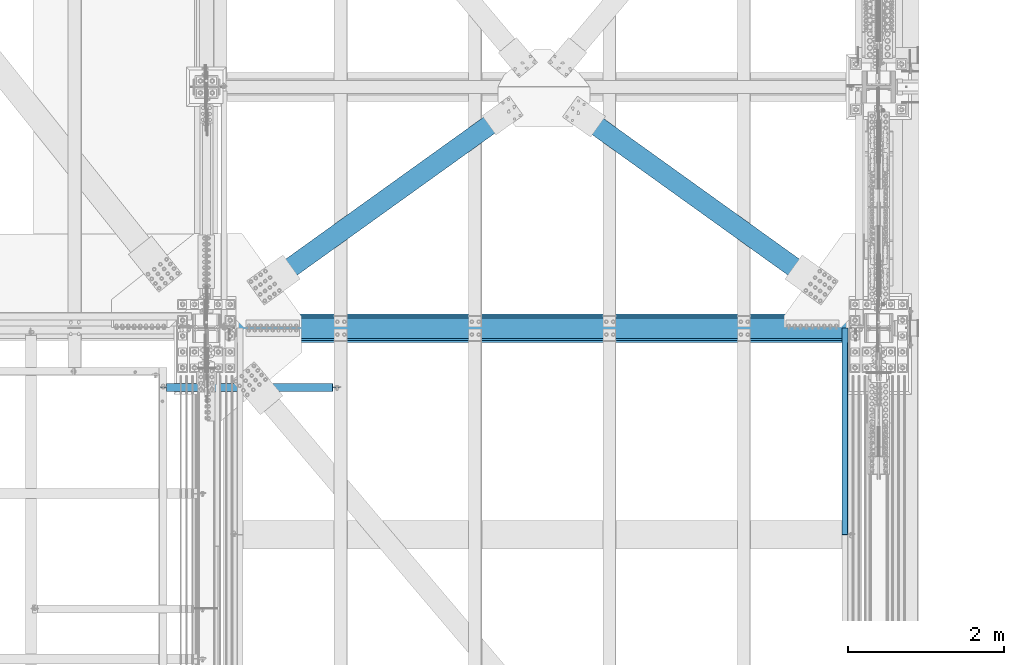
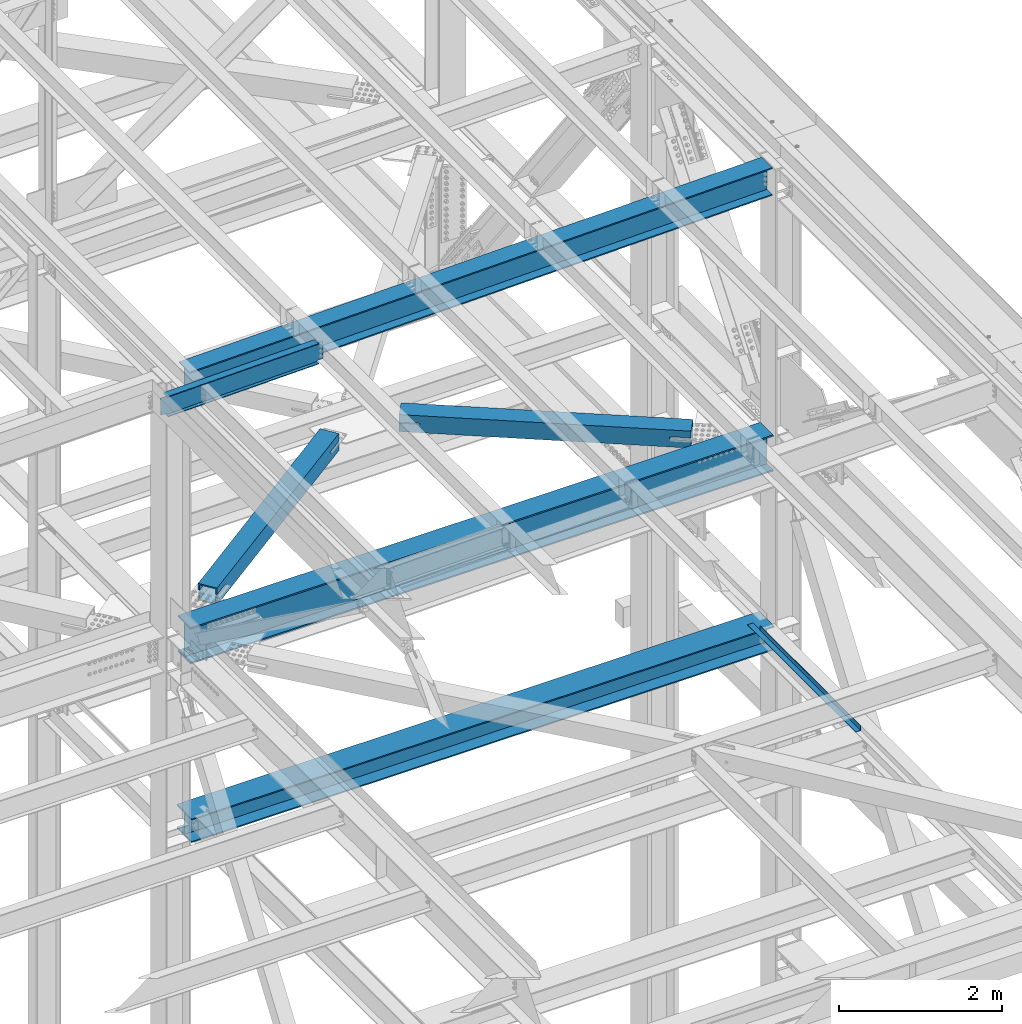
# One storey, part 1954 of 3843: 7 beams, 7 elements without a shape of their own.
"""IFC2X3 building model written with IfcOpenShell, lengths in millimetres."""

from ifc_helpers import new_model, si_unit, frame, origin_with_axes, place, context, subcontext, project, spatial, faceted_brep, material, type_object, element, aggregate, save


model = new_model("IFC2X3")

# Units and contexts
model_context = context("Model", 3, precision=1e-05, world=origin_with_axes())
body_context = subcontext(model_context, "Body", "Model", "MODEL_VIEW")
ifc_project = project(units=[si_unit("LENGTHUNIT", "METRE", prefix="MILLI"), si_unit("AREAUNIT", "SQUARE_METRE"), si_unit("VOLUMEUNIT", "CUBIC_METRE"), si_unit("MASSUNIT", "GRAM", prefix="KILO"), si_unit("TIMEUNIT", "SECOND"), si_unit("PLANEANGLEUNIT", "RADIAN"), si_unit("SOLIDANGLEUNIT", "STERADIAN"), si_unit("THERMODYNAMICTEMPERATUREUNIT", "DEGREE_CELSIUS"), si_unit("LUMINOUSINTENSITYUNIT", "LUMEN")], contexts=[model_context])

# Site, building, storey
site_placement = place(None, origin_with_axes())
site = spatial("IfcSite", under=ifc_project, at=site_placement, CompositionType="ELEMENT")
building_placement = place(site_placement, origin_with_axes())
building = spatial("IfcBuilding", under=site, at=building_placement, Name="Undefined", CompositionType="ELEMENT")
storey_placement = place(building_placement, origin_with_axes())
storey = spatial("IfcBuildingStorey", under=building, at=storey_placement, Name="Undefined", CompositionType="ELEMENT", Elevation=0.0)

# Assembly, beam
assembly_1_placement = place(storey_placement, origin_with_axes())
assembly_1 = element("IfcElementAssembly", 1, at=assembly_1_placement, inside=storey, Name="BEAM", AssemblyPlace="NOTDEFINED", PredefinedType="RIGID_FRAME")
ifc_material_1 = material(Name="STEEL/A992")
beam_type_1 = type_object("IfcBeamType", Name="W21X101", PredefinedType="NOTDEFINED")
beam_1_placement = place(assembly_1_placement, frame((77012.8, 25615.9, 42197.3375), z_axis=(0.0, 0.0, 1.0), x_axis=(1.0, 0.0, 0.0)))
beam_1 = element("IfcBeam", 2, at=beam_1_placement, type_object=beam_type_1, material=ifc_material_1, Name="BEAM", ObjectType="W21X101", context=body_context, shape_type="Brep", body=[
    faceted_brep([(190.5, -155.575000000001, -271.462500000001), (190.5, 155.575000000001, -271.462500000001), (8439.15000000001, 155.575000000001, -271.462500000001), (8439.15000000001, -155.575000000001, -271.462500000001), (190.5, -155.575000000001, -250.824999999997), (190.5, -6.34999999999854, -250.824999999997), (190.5, -6.34999999999854, 250.824999999997), (190.5, -155.575000000001, 250.824999999997), (190.5, -155.575000000001, 271.462500000001), (190.5, 155.575000000001, 271.462500000001), (190.5, 155.575000000001, 250.824999999997), (190.5, 6.34999999999854, 250.824999999997), (190.5, 6.34999999999854, -250.824999999997), (190.5, 155.575000000001, -250.824999999997), (8439.15000000001, -155.575000000001, -250.824999999997), (8439.15000000001, -6.34999999999854, -250.824999999997), (8439.15000000001, -6.34999999999854, 250.824999999997), (8439.15000000001, -155.575000000001, 250.824999999997), (8439.15000000001, -155.575000000001, 271.462500000001), (8439.15000000001, 155.575000000001, 271.462500000001), (8439.15000000001, 155.575000000001, 250.824999999997), (8439.15000000001, 6.34999999999854, 250.824999999997), (8439.15000000001, 6.34999999999854, 207.962500000001), (8439.15000000001, 6.34999999999854, -175.037499999999), (8439.15000000001, 6.34999999999854, -250.824999999997), (8439.15000000001, 155.575000000001, -250.824999999997)], [[[0, 1, 2, 3]], [[0, 4, 5, 6, 7, 8, 9, 10, 11, 12, 13, 1]], [[5, 4, 14, 15]], [[6, 5, 15, 16]], [[7, 6, 16, 17]], [[8, 7, 17, 18]], [[9, 8, 18, 19]], [[10, 9, 19, 20]], [[11, 10, 20, 21]], [[12, 11, 21, 22, 23, 24]], [[13, 12, 24, 25]], [[1, 13, 25, 2]], [[24, 23, 22, 21, 20, 19, 18, 17, 16, 15, 14, 3, 2, 25]], [[4, 0, 3, 14]]]),
])
aggregate(assembly_1, [beam_1])

assembly_2_placement = place(storey_placement, origin_with_axes())
assembly_2 = element("IfcElementAssembly", 3, at=assembly_2_placement, inside=storey, Name="BEAM", AssemblyPlace="NOTDEFINED", PredefinedType="RIGID_FRAME")
beam_type_2 = type_object("IfcBeamType", Name="W12X19", PredefinedType="NOTDEFINED")
beam_2_placement = place(assembly_2_placement, frame((76406.4576296654, 24853.8999999989, 46418.2582400871), z_axis=(-0.0211520980073474, 0.0, 0.999776269347241), x_axis=(0.999776270257024, 0.0, 0.0211520550054619)))
beam_2 = element("IfcBeam", 4, at=beam_2_placement, type_object=beam_type_2, material=ifc_material_1, Name="BEAM", ObjectType="W12X19", context=body_context, shape_type="Brep", body=[
    faceted_brep([(2232.31457436798, -3.17499999999927, -144.462499994821), (2232.31457436798, -50.7999999999993, -144.462499994821), (2232.31457436799, -50.7999999999993, -153.98749999483), (2232.31457436799, 50.7999999999993, -153.98749999483), (2232.31457436798, 50.7999999999993, -144.462499994821), (2232.31457436798, 3.17499999999927, -144.462499994821), (2232.31457436796, 3.17499999999927, -141.287499723039), (2232.31457436796, -3.17499999999927, -141.287499723039), (2233.28130429053, 3.17499999999927, -136.427420204993), (2233.28130429053, -3.17499999999927, -136.427420204993), (2236.03431819094, 3.17499999999927, -132.307243736817), (2236.03431819094, -3.17499999999927, -132.307243736817), (2240.154494659, 3.17499999999927, -129.554229836329), (2240.154494659, -3.17499999999927, -129.554229836329), (2245.01457417695, 3.17499999999927, -128.587499913723), (2245.01457417695, -3.17499999999927, -128.587499913723), (2314.86448693209, -3.17499999999927, -128.587499913519), (2314.86448693209, 3.17499999999927, -128.587499913519), (96.8369960211567, 3.17499999999927, 144.4625000003), (96.8369960211567, 50.7999999999993, 144.4625000003), (2232.3145743674, 50.7999999999993, 144.462500005327), (2232.3145743674, 3.17499999999927, 144.462500005327), (96.8369999801071, -3.17499999999927, -141.287529930967), (96.8369999801071, 3.17499999999927, -141.287529930967), (96.8369989925268, 3.17499999999927, -144.462499999849), (96.8369989925268, 50.7999999999993, -144.462499999849), (96.8369960297132, 50.7999999999993, -153.987499999843), (96.8369960297132, -50.7999999999993, -153.987499999843), (96.8369989925268, -50.7999999999993, -144.462499999849), (96.8369989925268, -3.17499999999927, -144.462499999849), (95.8702715693071, -3.17499999999927, -136.42745011222), (95.8702715693071, 3.17499999999927, -136.42745011222), (93.1172589504567, -3.17499999999927, -132.30727278773), (93.1172589504567, 3.17499999999927, -132.30727278773), (88.997083338676, -3.17499999999927, -129.55425760564), (88.997083338676, 3.17499999999927, -129.55425760564), (84.1370041213813, -3.17499999999927, -128.587526171294), (84.1370041213813, 3.17499999999927, -128.587526171294), (20.637003929136, -3.17499999999927, -128.587506419208), (20.637003929136, 3.17499999999927, -128.587506419208), (20.6370839253505, -3.17499999999927, 128.587493580635), (20.6370839253505, 3.17499999999927, 128.587493580635), (20.6370799748984, 3.17499999999927, 115.887493577924), (20.6370082450449, 3.17499999999927, -114.71250641709), (84.1369962121535, -3.17499999999927, 128.58750000054), (84.1369962121535, 3.17499999999927, 128.58750000054), (88.9970757301198, -3.17499999999927, 129.554229923146), (88.9970757301198, 3.17499999999927, 129.554229923146), (93.1172521981789, -3.17499999999927, 132.307243823634), (93.1172521981789, 3.17499999999927, 132.307243823634), (95.8702660985873, -3.17499999999927, 136.427420291802), (95.8702660985873, 3.17499999999927, 136.427420291802), (96.8369960211421, -3.17499999999927, 141.287499809849), (96.8369960211421, 3.17499999999927, 141.287499809849), (96.8369960211276, -50.7999999999993, 153.988180121596), (96.8369960211276, 50.7999999999993, 153.987500000301), (96.8369960211567, -3.17499999999927, 144.4625000003), (96.8369960211567, -50.7999999999993, 144.4625000003), (2232.3145743674, -3.17499999999927, 144.462500005327), (2232.3145743674, -50.7999999999993, 144.462500005327), (2232.31457436738, -50.7999999999993, 153.987525317927), (2232.31457436738, 50.7999999999993, 153.987500005329), (2232.3145743674, -3.17499999999927, 141.287499895916), (2232.3145743674, 3.17499999999927, 141.287499895916), (2233.28130428997, -3.17499999999927, 136.42742037787), (2233.28130428997, 3.17499999999927, 136.42742037787), (2236.03431819039, -3.17499999999927, 132.307243909716), (2236.03431819039, 3.17499999999927, 132.307243909716), (2240.15449465848, -3.17499999999927, 129.554230009235), (2240.15449465848, 3.17499999999927, 129.554230009235), (2245.01457417643, -3.17499999999927, 128.587500086658), (2245.01457417643, 3.17499999999927, 128.587500086658), (2314.8645669283, -3.17499999999927, 128.587500086825), (2314.8645669283, 3.17499999999927, 128.587500086825), (2314.86449124801, 3.17499999999927, -114.712513824932), (2314.86456297785, 3.17499999999927, 115.887486172294)], [[[0, 1, 2, 3, 4, 5, 6, 7]], [[7, 6, 8, 9]], [[9, 8, 10, 11]], [[11, 10, 12, 13]], [[13, 12, 14, 15]], [[16, 15, 14, 17]], [[18, 19, 20, 21]], [[22, 23, 24, 25, 26, 27, 28, 29]], [[30, 31, 23, 22]], [[32, 33, 31, 30]], [[34, 35, 33, 32]], [[36, 37, 35, 34]], [[38, 39, 37, 36]], [[40, 41, 42, 43, 39, 38]], [[44, 45, 41, 40]], [[46, 47, 45, 44]], [[48, 49, 47, 46]], [[50, 51, 49, 48]], [[52, 53, 51, 50]], [[54, 55, 19, 18, 53, 52, 56, 57]], [[57, 56, 58, 59]], [[54, 57, 59, 60]], [[55, 54, 60, 61]], [[19, 55, 61, 20]], [[60, 59, 58, 62, 63, 21, 20, 61]], [[64, 65, 63, 62]], [[66, 67, 65, 64]], [[68, 69, 67, 66]], [[70, 71, 69, 68]], [[72, 73, 71, 70]], [[74, 75, 73, 72, 16, 17]], [[12, 10, 8, 6, 5, 24, 23, 31, 33, 35, 37, 39, 43, 42, 41, 45, 47, 49, 51, 53, 18, 21, 63, 65, 67, 69, 71, 73, 75, 74, 17, 14]], [[25, 24, 5, 4]], [[26, 25, 4, 3]], [[27, 26, 3, 2]], [[28, 27, 2, 1]], [[29, 28, 1, 0]], [[72, 70, 68, 66, 64, 62, 58, 56, 52, 50, 48, 46, 44, 40, 38, 36, 34, 32, 30, 22, 29, 0, 7, 9, 11, 13, 15, 16]]]),
])
aggregate(assembly_2, [beam_2])

assembly_3_placement = place(storey_placement, origin_with_axes())
assembly_3 = element("IfcElementAssembly", 5, at=assembly_3_placement, inside=storey, Name="BENT_PLATE", AssemblyPlace="NOTDEFINED", PredefinedType="RIGID_FRAME")
ifc_material_2 = material(Name="STEEL/A36")
beam_type_3 = type_object("IfcBeamType", PredefinedType="NOTDEFINED")
beam_3_placement = place(assembly_3_placement, frame((85177.3124999996, 24288.75, 39627.1750000005), z_axis=(0.0, 1.0, 0.0), x_axis=(1.0, 0.0, 0.0)))
beam_3 = element("IfcBeam", 6, at=beam_3_placement, type_object=beam_type_3, material=ifc_material_2, Name="BENT_PLATE", context=body_context, shape_type="Brep", body=[
    faceted_brep([(73.0249999527732, -4.71118255518377e-08, -1327.15), (69.8499999999767, -3.17499999968277, -1323.97500004769), (1.45519152283669e-11, -3.17500000000291, -1323.97500004769), (0.0, -4.74465196020901e-08, -1327.15), (73.0249999533989, -73.024999999252, -1327.15), (69.8500000005733, -73.0249999992811, -1323.97500004769), (69.8499999999767, -3.17499999968277, 1142.99999999999), (69.8499999999767, -3.17499999968277, 1327.15), (1.45519152283669e-11, -3.17500000000291, 1327.15), (76.2000000005792, -73.0249999992229, 1143.0), (76.1999999999825, -3.17499999977008, 1142.99999999999), (69.8500000005733, -73.0249999992811, 1143.0), (76.1999999999825, -3.1749999997628, 1327.14999999999), (-1.45519152283669e-11, 3.17500000000291, -1327.15), (76.1999999999243, 3.17500000035216, -1327.15), (76.2000000005792, -73.0249999992229, -1327.15), (-1.45519152283669e-11, 3.17500000000291, 1327.15), (76.1999999999243, 3.17500000035216, 1327.15)], [[[0, 1, 2, 3]], [[4, 5, 1, 0]], [[6, 7, 8, 2, 1]], [[9, 10, 6, 11]], [[12, 7, 6, 10]], [[13, 14, 15, 4, 0, 3]], [[8, 16, 13, 3, 2]], [[13, 16, 17, 14]], [[9, 15, 14, 17, 12, 10]], [[15, 9, 11, 5, 4]], [[11, 6, 1, 5]], [[17, 16, 8, 7, 12]]]),
])
aggregate(assembly_3, [beam_3])

assembly_4_placement = place(storey_placement, origin_with_axes())
assembly_4 = element("IfcElementAssembly", 7, at=assembly_4_placement, inside=storey, AssemblyPlace="NOTDEFINED", PredefinedType="RIGID_FRAME")
ifc_material_3 = material()
beam_type_4 = type_object("IfcBeamType", Name="HSS10X10X3/4", PredefinedType="NOTDEFINED")
beam_4_placement = place(assembly_4_placement, frame((81330.8000041454, 28714.7000040427, 42246.55), z_axis=(0.583045051917548, 0.812439823885107, 0.0), x_axis=(0.81243982388511, -0.583045051917543, 0.0)))
beam_4 = element("IfcBeam", 8, at=beam_4_placement, type_object=beam_type_4, material=ifc_material_3, ObjectType="HSS10X10X3/4", context=body_context, shape_type="Brep", body=[
    faceted_brep([(832.719836871249, 1.58750000000146, 127.000000000786), (832.719836871307, 1.58750000000146, 107.950000000856), (875.816558129489, 1.58750000000146, 107.950000000914), (875.816558129431, 1.58750000000146, 127.000000000844), (878.8541078739, 0.983293789307936, 107.950000000914), (878.854107873842, 0.983293789307936, 127.000000000844), (881.429218205194, -0.737339924329717, 107.950000000928), (881.429218205121, -0.737339924329717, 127.000000000844), (883.149851918824, -3.31245025560202, 107.950000000928), (883.149851918752, -3.31245025560202, 127.000000000844), (875.816558129431, -14.2874999999985, 127.000000000844), (875.816558129489, -14.2874999999985, 107.950000000914), (832.719836871307, -14.2874999999985, 107.950000000856), (832.719836871249, -14.2874999999985, 127.000000000786), (878.854107873842, -13.683293789305, 127.000000000844), (878.8541078739, -13.683293789305, 107.950000000914), (881.429218205121, -11.9626600756674, 127.000000000844), (881.429218205194, -11.9626600756674, 107.950000000928), (883.149851918752, -9.38754974439507, 127.000000000844), (883.149851918824, -9.38754974439507, 107.950000000928), (883.754058129467, -6.34999999999854, 127.000000000859), (883.754058129525, -6.34999999999854, 107.950000000914), (832.719836872006, 1.58750000000146, -107.949999998309), (832.719836872064, 1.58750000000146, -126.999999998239), (875.816558130238, 1.58750000000146, -126.999999998166), (875.81655813018, 1.58750000000146, -107.949999998236), (878.854107874657, 0.983293789307936, -126.999999998166), (878.854107874598, 0.983293789307936, -107.949999998236), (881.429218205936, -0.737339924329717, -126.999999998166), (881.429218205878, -0.737339924329717, -107.949999998236), (883.149851919581, -3.31245025560202, -126.999999998166), (883.149851919508, -3.31245025560202, -107.949999998236), (875.81655813018, -14.2874999999985, -107.949999998236), (875.816558130238, -14.2874999999985, -126.999999998166), (832.719836872064, -14.2874999999985, -126.999999998239), (832.719836872006, -14.2874999999985, -107.949999998309), (878.854107874598, -13.683293789305, -107.949999998236), (878.854107874657, -13.683293789305, -126.999999998166), (881.429218205878, -11.9626600756674, -107.949999998236), (881.429218205936, -11.9626600756674, -126.999999998166), (883.149851919508, -9.38754974439507, -107.949999998236), (883.149851919581, -9.38754974439507, -126.999999998166), (883.754058130216, -6.34999999999854, -107.949999998236), (883.75405813026, -6.34999999999854, -126.999999998166), (623.404058128544, 127.0, -126.999999998559), (623.404058128326, 127.0, 127.000000000451), (4220.92128598434, 127.0, 127.000000005952), (4220.92128598454, 127.0, -126.999999993059), (623.404058128326, -127.0, 127.000000000451), (623.404058128544, -127.0, -126.999999998559), (4220.92128598454, -127.0, -126.999999993059), (4220.92128598434, -127.0, 127.000000005952), (4220.92128598453, 1.58750000000146, -107.949999993143), (3968.5087863602, 1.58750000000146, -107.949999993521), (3968.50878636027, 1.58750000000146, -126.999999993452), (4220.92128598454, 1.58750000000146, -126.999999993059), (3963.04119667428, 0.499928791716229, -107.949999993521), (3963.04119667436, 0.499928791716229, -126.999999993452), (3958.40599795424, -2.59721197552426, -107.949999993536), (3958.40599795429, -2.59721197552426, -126.999999993452), (3955.30885718697, -7.23241069557116, -107.949999993551), (3955.30885718704, -7.23241069557116, -126.999999993466), (3954.2212859787, -12.6999996185259, -107.949999993536), (3954.22128597875, -12.6999996185259, -126.999999993481), (3955.30885718697, -18.167589304423, -107.949999993551), (3955.30885718704, -18.167589304423, -126.999999993466), (3958.40599795424, -22.8027880244699, -107.949999993536), (3958.40599795429, -22.8027880244699, -126.999999993452), (3963.04119667428, -25.8999287917104, -107.949999993521), (3963.04119667436, -25.8999287917104, -126.999999993452), (3968.5087863602, -26.9874999999956, -107.949999993521), (3968.50878636027, -26.9874999999956, -126.999999993452), (4220.92128598453, -26.9874999999956, -107.949999993143), (4220.92128598454, -26.9874999999956, -126.999999993059), (623.40405812853, -107.949999999997, -107.949999998629), (623.404058128341, -107.949999999997, 107.950000000521), (4220.92128598435, -107.949999999997, 107.950000006022), (4220.92128598453, -107.949999999997, -107.949999993143), (4220.92128598435, -26.9874999999956, 107.950000006022), (4220.92128598434, -26.9874999999956, 127.000000005952), (3968.50878635952, -26.9874999999956, 107.950000005629), (3968.50878635946, -26.9874999999956, 127.000000005559), (3963.0411966736, -25.8999287917104, 107.950000005629), (3963.04119667354, -25.8999287917104, 127.000000005559), (3958.40599795354, -22.8027880244699, 107.950000005629), (3958.40599795348, -22.8027880244699, 127.000000005544), (3955.30885718628, -18.167589304423, 107.950000005614), (3955.30885718621, -18.167589304423, 127.000000005544), (3954.22128597799, -12.6999996185259, 107.950000005614), (3954.22128597795, -12.6999996185259, 127.000000005544), (3955.30885718628, -7.23241069557116, 107.950000005614), (3955.30885718621, -7.23241069557116, 127.000000005544), (3958.40599795354, -2.59721197552426, 107.950000005629), (3958.40599795348, -2.59721197552426, 127.000000005544), (3963.0411966736, 0.499928791716229, 107.950000005629), (3963.04119667354, 0.499928791716229, 127.000000005559), (3968.50878635952, 1.58750000000146, 107.950000005629), (3968.50878635946, 1.58750000000146, 127.000000005559), (4220.92128598434, 1.58750000000146, 127.000000005952), (4220.92128598435, 1.58750000000146, 107.950000006022), (4220.92128598435, 107.949999999997, 107.950000006022), (4220.92128598453, 107.949999999997, -107.949999993143), (623.404058128341, 107.949999999997, 107.950000000521), (623.40405812853, 107.949999999997, -107.949999998629), (623.404058128544, 1.58750000000146, -126.999999998559), (623.40405812853, 1.58750000000146, -107.949999998629), (623.404058128341, 1.58750000000146, 107.950000000521), (623.404058128326, 1.58750000000146, 127.000000000451), (623.404058128326, -14.2874999999985, 127.000000000451), (623.404058128341, -14.2874999999985, 107.950000000521), (623.40405812853, -14.2874999999985, -107.949999998629), (623.404058128544, -14.2874999999985, -126.999999998559)], [[[0, 1, 2, 3]], [[3, 2, 4, 5]], [[5, 4, 6, 7]], [[7, 6, 8, 9]], [[10, 11, 12, 13]], [[14, 15, 11, 10]], [[16, 17, 15, 14]], [[18, 19, 17, 16]], [[20, 21, 19, 18]], [[9, 8, 21, 20]], [[22, 23, 24, 25]], [[25, 24, 26, 27]], [[27, 26, 28, 29]], [[29, 28, 30, 31]], [[32, 33, 34, 35]], [[36, 37, 33, 32]], [[38, 39, 37, 36]], [[40, 41, 39, 38]], [[42, 43, 41, 40]], [[31, 30, 43, 42]], [[44, 45, 46, 47]], [[48, 49, 50, 51]], [[52, 53, 54, 55]], [[56, 57, 54, 53]], [[58, 59, 57, 56]], [[60, 61, 59, 58]], [[62, 63, 61, 60]], [[64, 65, 63, 62]], [[66, 67, 65, 64]], [[68, 69, 67, 66]], [[70, 71, 69, 68]], [[72, 73, 71, 70]], [[74, 75, 76, 77]], [[51, 50, 73, 72, 77, 76, 78, 79]], [[79, 78, 80, 81]], [[81, 80, 82, 83]], [[83, 82, 84, 85]], [[85, 84, 86, 87]], [[87, 86, 88, 89]], [[89, 88, 90, 91]], [[91, 90, 92, 93]], [[93, 92, 94, 95]], [[95, 94, 96, 97]], [[98, 97, 96, 99]], [[100, 101, 52, 55, 47, 46, 98, 99]], [[102, 103, 101, 100]], [[45, 44, 104, 105, 103, 102, 106, 107]], [[107, 106, 1, 0]], [[16, 14, 10, 13, 108, 48, 51, 79, 81, 83, 85, 87, 89, 91, 93, 95, 97, 98, 46, 45, 107, 0, 3, 5, 7, 9, 20, 18]], [[6, 4, 2, 1, 106, 102, 100, 99, 96, 94, 92, 90, 88, 86, 84, 82, 80, 78, 76, 75, 109, 12, 11, 15, 17, 19, 21, 8]], [[13, 12, 109, 108]], [[75, 74, 110, 111, 49, 48, 108, 109]], [[35, 34, 111, 110]], [[28, 26, 24, 23, 104, 44, 47, 55, 54, 57, 59, 61, 63, 65, 67, 69, 71, 73, 50, 49, 111, 34, 33, 37, 39, 41, 43, 30]], [[105, 104, 23, 22]], [[38, 36, 32, 35, 110, 74, 77, 72, 70, 68, 66, 64, 62, 60, 58, 56, 53, 52, 101, 103, 105, 22, 25, 27, 29, 31, 42, 40]]]),
])
aggregate(assembly_4, [beam_4])

assembly_5_placement = place(storey_placement, origin_with_axes())
assembly_5 = element("IfcElementAssembly", 9, at=assembly_5_placement, inside=storey, AssemblyPlace="NOTDEFINED", PredefinedType="RIGID_FRAME")
beam_5_placement = place(assembly_5_placement, frame((77012.8, 25615.9, 42246.55), z_axis=(0.583045050783809, -0.812439824698731, 0.0), x_axis=(0.812439824698741, 0.583045050783796, 0.0)))
beam_5 = element("IfcBeam", 10, at=beam_5_placement, type_object=beam_type_4, material=ifc_material_3, ObjectType="HSS10X10X3/4", context=body_context, shape_type="Brep", body=[
    faceted_brep([(4482.13534065839, 14.2874999999985, 127.000000001219), (4469.43534061559, 14.2874999999985, 127.000000001219), (4469.43534061576, 14.2874999999985, 107.950000001289), (4482.13534065855, 14.2874999999985, 107.950000001289), (4466.39779087117, 13.683293789305, 127.000000001215), (4466.39779087133, 13.683293789305, 107.950000001285), (4463.82268053987, 11.9626600756674, 127.000000001219), (4463.82268054002, 11.9626600756674, 107.950000001285), (4462.1020468262, 9.38754974439507, 127.000000001211), (4462.10204682636, 9.38754974439507, 107.950000001281), (4461.4978406155, 6.34999999999854, 127.000000001215), (4461.49784061566, 6.34999999999854, 107.950000001281), (4462.1020468262, 3.31245025560202, 127.000000001211), (4462.10204682636, 3.31245025560202, 107.950000001281), (4463.82268053987, 0.737339924329717, 127.000000001219), (4463.82268054002, 0.737339924329717, 107.950000001285), (4466.39779087117, -0.983293789307936, 127.000000001215), (4466.39779087133, -0.983293789307936, 107.950000001285), (4469.43534061559, -1.58750000000146, 127.000000001219), (4469.43534061576, -1.58750000000146, 107.950000001289), (4482.13534065839, -1.58750000000146, 127.000000001219), (4482.13534065855, -1.58750000000146, 107.950000001289), (4482.13534066027, 14.2874999999985, -107.949999997931), (4469.43534061746, 14.2874999999985, -107.949999997938), (4469.43534061762, 14.2874999999985, -126.999999997868), (4482.13534066042, 14.2874999999985, -126.999999997865), (4466.39779087304, 13.683293789305, -107.949999997938), (4466.39779087319, 13.683293789305, -126.999999997868), (4463.82268054174, 11.9626600756674, -107.949999997934), (4463.8226805419, 11.9626600756674, -126.999999997861), (4462.10204682808, 9.38754974439507, -107.949999997938), (4462.10204682824, 9.38754974439507, -126.999999997865), (4461.49784061739, 6.34999999999854, -107.949999997934), (4461.49784061754, 6.34999999999854, -126.999999997865), (4462.10204682808, 3.31245025560202, -107.949999997938), (4462.10204682824, 3.31245025560202, -126.999999997865), (4463.82268054174, 0.737339924329717, -107.949999997934), (4463.8226805419, 0.737339924329717, -126.999999997861), (4466.39779087304, -0.983293789307936, -107.949999997938), (4466.39779087319, -0.983293789307936, -126.999999997868), (4469.43534061746, -1.58750000000146, -107.949999997938), (4469.43534061762, -1.58750000000146, -126.999999997868), (4482.13534066027, -1.58750000000146, -107.949999997931), (4482.13534066042, -1.58750000000146, -126.999999997865), (1093.93388031794, -107.949999999997, -107.9499999992), (1093.93388031713, -107.949999999997, 107.950000000023), (4721.84784061975, -107.949999999997, 107.950000001376), (4721.84784062057, -107.949999999997, -107.949999997847), (1346.34637994521, -1.58750000000146, -107.949999999102), (1346.34637994536, -1.58750000000146, -126.999999999032), (1093.93388031801, -1.58750000000146, -126.999999999138), (1093.93388031794, -1.58750000000146, -107.9499999992), (1351.81396963117, -0.499928791716229, -107.949999999099), (1351.81396963132, -0.499928791716229, -126.999999999036), (1356.44916835126, 2.59721197552426, -107.949999999102), (1356.44916835142, 2.59721197552426, -126.999999999029), (1359.54630911854, 7.23241069557116, -107.949999999095), (1359.54630911868, 7.23241069557116, -126.999999999032), (1360.63388032683, 12.6999996185259, -107.949999999095), (1360.63388032698, 12.6999996185259, -126.99999999904), (1359.54630911854, 18.167589304423, -107.949999999095), (1359.54630911868, 18.167589304423, -126.999999999032), (1356.44916835126, 22.8027880244699, -107.949999999102), (1356.44916835142, 22.8027880244699, -126.999999999029), (1351.81396963117, 25.8999287917104, -107.949999999099), (1351.81396963132, 25.8999287917104, -126.999999999036), (1346.34637994521, 26.9874999999956, -107.949999999102), (1346.34637994536, 26.9874999999956, -126.999999999032), (1093.93388031794, 26.9874999999956, -107.9499999992), (1093.93388031801, 26.9874999999956, -126.999999999138), (1093.93388031713, 107.949999999997, 107.950000000023), (1093.93388031794, 107.949999999997, -107.9499999992), (4721.84784062057, 107.949999999997, -107.949999997847), (4721.84784061975, 107.949999999997, 107.950000001376), (1351.81396962929, -0.499928791716229, 127.000000000055), (1351.81396962945, -0.499928791716229, 107.950000000117), (1346.3463799435, -1.58750000000146, 107.950000000114), (1346.34637994334, -1.58750000000146, 127.000000000051), (1356.4491683494, 2.59721197552426, 127.000000000051), (1356.44916834954, 2.59721197552426, 107.950000000117), (1359.54630911667, 7.23241069557116, 127.000000000051), (1359.54630911682, 7.23241069557116, 107.950000000121), (1360.63388032497, 12.6999996185259, 127.000000000051), (1360.63388032511, 12.6999996185259, 107.950000000124), (1359.54630911667, 18.167589304423, 127.000000000051), (1359.54630911682, 18.167589304423, 107.950000000121), (1356.4491683494, 22.8027880244699, 127.000000000051), (1356.44916834954, 22.8027880244699, 107.950000000117), (1351.81396962929, 25.8999287917104, 127.000000000055), (1351.81396962945, 25.8999287917104, 107.950000000117), (1346.34637994334, 26.9874999999956, 127.000000000051), (1346.3463799435, 26.9874999999956, 107.950000000114), (1093.93388031707, 26.9874999999956, 126.999999999953), (1093.93388031713, 26.9874999999956, 107.950000000023), (1093.93388031707, 127.0, 126.999999999953), (1093.93388031801, 127.0, -126.999999999138), (4721.84784061968, 127.0, 127.00000000131), (4721.84784062064, 127.0, -126.999999997774), (4721.84784062057, 14.2874999999985, -107.949999997847), (4721.84784062064, 14.2874999999985, -126.999999997774), (4721.84784061968, 14.2874999999985, 127.00000000131), (4721.84784061975, 14.2874999999985, 107.950000001376), (4721.84784061975, -1.58750000000146, 107.950000001376), (1093.93388031713, -1.58750000000146, 107.950000000023), (1093.93388031707, -1.58750000000146, 126.999999999953), (1093.93388031801, -127.0, -126.999999999138), (1093.93388031707, -127.0, 126.999999999953), (4721.84784062064, -127.0, -126.999999997774), (4721.84784061968, -127.0, 127.00000000131), (4721.84784061968, -1.58750000000146, 127.00000000131), (4721.84784062064, -1.58750000000146, -126.999999997774), (4721.84784062057, -1.58750000000146, -107.949999997847)], [[[0, 1, 2, 3]], [[4, 5, 2, 1]], [[6, 7, 5, 4]], [[8, 9, 7, 6]], [[10, 11, 9, 8]], [[12, 13, 11, 10]], [[14, 15, 13, 12]], [[16, 17, 15, 14]], [[18, 19, 17, 16]], [[20, 21, 19, 18]], [[22, 23, 24, 25]], [[26, 27, 24, 23]], [[28, 29, 27, 26]], [[30, 31, 29, 28]], [[32, 33, 31, 30]], [[34, 35, 33, 32]], [[36, 37, 35, 34]], [[38, 39, 37, 36]], [[40, 41, 39, 38]], [[42, 43, 41, 40]], [[44, 45, 46, 47]], [[48, 49, 50, 51]], [[52, 53, 49, 48]], [[54, 55, 53, 52]], [[56, 57, 55, 54]], [[58, 59, 57, 56]], [[60, 61, 59, 58]], [[62, 63, 61, 60]], [[64, 65, 63, 62]], [[66, 67, 65, 64]], [[68, 69, 67, 66]], [[70, 71, 72, 73]], [[74, 75, 76, 77]], [[78, 79, 75, 74]], [[80, 81, 79, 78]], [[82, 83, 81, 80]], [[84, 85, 83, 82]], [[86, 87, 85, 84]], [[88, 89, 87, 86]], [[90, 91, 89, 88]], [[92, 93, 91, 90]], [[94, 95, 69, 68, 71, 70, 93, 92]], [[95, 94, 96, 97]], [[73, 72, 98, 99, 97, 96, 100, 101]], [[100, 0, 3, 101]], [[102, 46, 45, 103, 76, 75, 79, 81, 83, 85, 87, 89, 91, 93, 70, 73, 101, 3, 2, 5, 7, 9, 11, 13, 15, 17, 19, 21]], [[77, 76, 103, 104]], [[45, 44, 51, 50, 105, 106, 104, 103]], [[106, 105, 107, 108]], [[16, 14, 12, 10, 8, 6, 4, 1, 0, 100, 96, 94, 92, 90, 88, 86, 84, 82, 80, 78, 74, 77, 104, 106, 108, 109, 20, 18]], [[109, 102, 21, 20]], [[108, 107, 110, 111, 47, 46, 102, 109]], [[38, 36, 34, 32, 30, 28, 26, 23, 22, 98, 72, 71, 68, 66, 64, 62, 60, 58, 56, 54, 52, 48, 51, 44, 47, 111, 42, 40]], [[98, 22, 25, 99]], [[110, 107, 105, 50, 49, 53, 55, 57, 59, 61, 63, 65, 67, 69, 95, 97, 99, 25, 24, 27, 29, 31, 33, 35, 37, 39, 41, 43]], [[111, 110, 43, 42]]]),
])
aggregate(assembly_5, [beam_5])

assembly_6_placement = place(storey_placement, origin_with_axes())
assembly_6 = element("IfcElementAssembly", 11, at=assembly_6_placement, inside=storey, Name="BEAM", AssemblyPlace="NOTDEFINED", PredefinedType="RIGID_FRAME")
beam_type_5 = type_object("IfcBeamType", Name="W16X67", PredefinedType="NOTDEFINED")
beam_6_placement = place(assembly_6_placement, frame((77017.1988428479, 25615.9, 46065.9736071223), z_axis=(-0.0211520980073474, 0.0, 0.999776269347241), x_axis=(0.999776270257024, 0.0, 0.0211520550054619)))
beam_6 = element("IfcBeam", 12, at=beam_6_placement, type_object=beam_type_5, material=ifc_material_1, Name="BEAM", ObjectType="W16X67", context=body_context, shape_type="Brep", body=[
    faceted_brep([(181.742975470595, -130.174999999999, -207.962499999499), (181.742975470595, 130.174999999999, -207.962499999499), (8432.23886485929, 130.174999999999, -207.962499992493), (8432.23886485929, -130.174999999999, -207.962499992493), (182.112426639622, -130.174999999999, -190.499999999527), (182.112426639622, -4.76250000000073, -190.499999999527), (190.173179417936, -4.76250000000073, 190.499999999862), (190.173179417936, -130.174999999999, 190.499999999862), (190.542630586948, -130.174999999999, 207.962499999841), (190.542630586948, 130.174999999999, 207.962499999841), (190.173179417936, 130.174999999999, 190.499999999862), (190.173179417936, 4.76250000000073, 190.499999999862), (182.112426639622, 4.76250000000073, -190.499999999527), (182.112426639622, 130.174999999999, -190.499999999527), (8432.60831602832, -130.174999999999, -190.49999999252), (8432.60831602832, -4.76250000000073, -190.49999999252), (8440.66906880663, -4.76250000000073, 190.500000006876), (8440.66906880663, -130.174999999999, 190.500000006876), (8441.03851997564, -130.174999999999, 207.962500006841), (8441.03851997564, 130.174999999999, 207.962500006841), (8440.66906880663, 130.174999999999, 190.500000006876), (8440.66906880663, 4.76250000000073, 190.500000006876), (8432.60831602832, 4.76250000000073, -190.49999999252), (8432.60831602832, 130.174999999999, -190.49999999252)], [[[0, 1, 2, 3]], [[0, 4, 5, 6, 7, 8, 9, 10, 11, 12, 13, 1]], [[5, 4, 14, 15]], [[6, 5, 15, 16]], [[7, 6, 16, 17]], [[8, 7, 17, 18]], [[9, 8, 18, 19]], [[10, 9, 19, 20]], [[11, 10, 20, 21]], [[12, 11, 21, 22]], [[13, 12, 22, 23]], [[1, 13, 23, 2]], [[22, 21, 20, 19, 18, 17, 16, 15, 14, 3, 2, 23]], [[4, 0, 3, 14]]]),
])
aggregate(assembly_6, [beam_6])

assembly_7_placement = place(storey_placement, origin_with_axes())
assembly_7 = element("IfcElementAssembly", 13, at=assembly_7_placement, inside=storey, Name="BEAM", AssemblyPlace="NOTDEFINED", PredefinedType="RIGID_FRAME")
beam_type_6 = type_object("IfcBeamType", Name="W14X90", PredefinedType="NOTDEFINED")
beam_7_placement = place(assembly_7_placement, frame((77012.8, 25615.9, 39446.2), z_axis=(0.0, 0.0, 1.0), x_axis=(1.0, 0.0, 0.0)))
beam_7 = element("IfcBeam", 14, at=beam_7_placement, type_object=beam_type_6, material=ifc_material_1, Name="BEAM", ObjectType="W14X90", context=body_context, shape_type="Brep", body=[
    faceted_brep([(190.499999999985, 184.149999999994, -177.800000000003), (190.499999999985, 184.149999999994, -160.337500000001), (8439.14999999999, 184.149999999994, -160.337500000001), (8439.14999999999, 184.149999999994, -177.800000000003), (190.499999999985, 5.55624999999418, -160.337500000001), (8439.14999999999, 5.55624999999418, -160.337500000001), (190.499999999985, 5.55624999999418, 160.337500000001), (8439.14999999999, 5.55624999999418, 160.337500000001), (190.499999999985, 184.149999999994, 160.337500000001), (8439.14999999999, 184.149999999994, 160.337500000001), (190.499999999985, 184.149999999994, 177.800000000003), (8439.14999999999, 184.149999999994, 177.800000000003), (190.499999999985, -184.149999999994, 177.800000000003), (8439.14999999999, -184.149999999994, 177.800000000003), (190.499999999985, -184.149999999994, 160.337500000001), (8439.14999999999, -184.149999999994, 160.337500000001), (190.499999999985, -5.55624999999418, 160.337500000001), (8439.14999999999, -5.55624999999418, 160.337500000001), (190.499999999985, -5.55624999999418, -160.337500000001), (8439.14999999999, -5.55624999999418, -160.337500000001), (190.499999999985, -184.149999999994, -160.337500000001), (8439.14999999999, -184.149999999994, -160.337500000001), (190.499999999985, -184.149999999994, -177.800000000003), (8439.14999999999, -184.149999999994, -177.800000000003)], [[[0, 1, 2, 3]], [[1, 4, 5, 2]], [[4, 6, 7, 5]], [[6, 8, 9, 7]], [[8, 10, 11, 9]], [[10, 12, 13, 11]], [[12, 14, 15, 13]], [[14, 16, 17, 15]], [[16, 18, 19, 17]], [[18, 20, 21, 19]], [[20, 22, 23, 21]], [[22, 0, 3, 23]], [[5, 7, 9, 11, 13, 15, 17, 19, 21, 23, 3, 2]], [[22, 20, 18, 16, 14, 12, 10, 8, 6, 4, 1, 0]]]),
])
aggregate(assembly_7, [beam_7])

save(model, "model.ifc")
